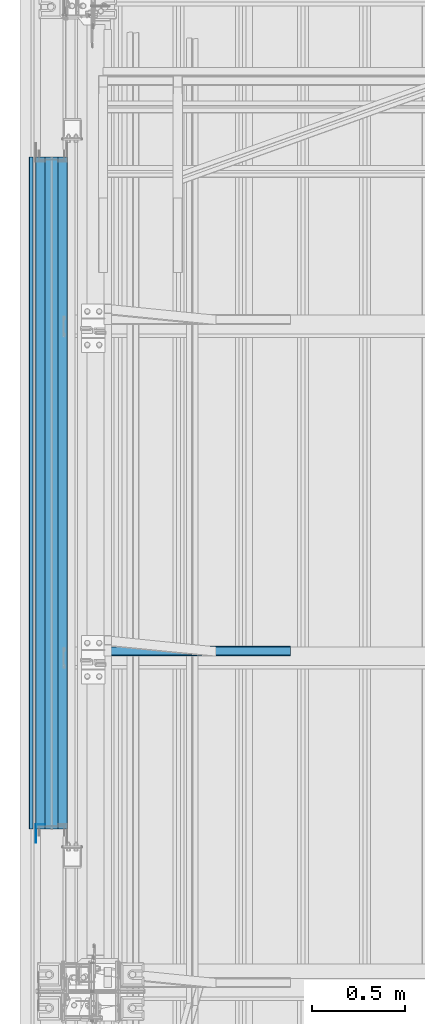
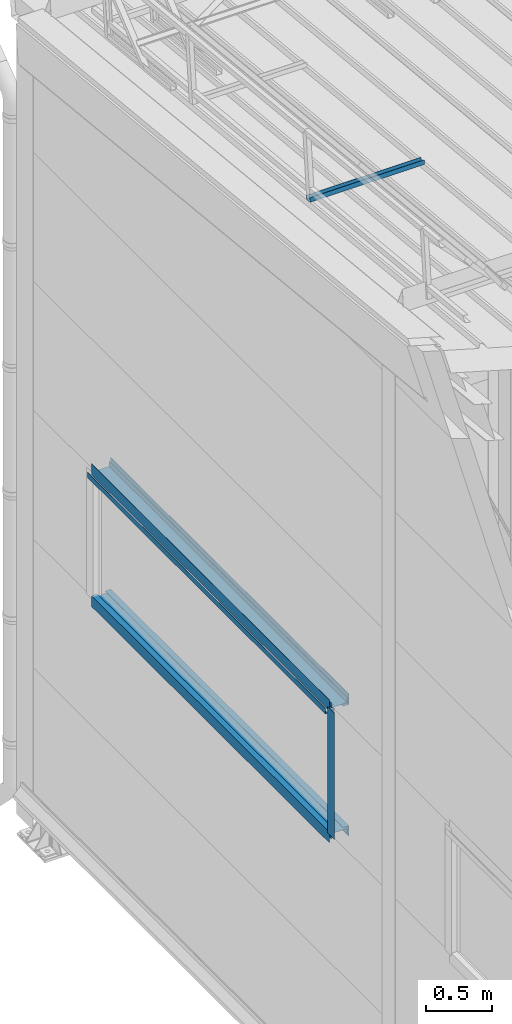
# One storey, part 49 of 709: 9 beams, 9 elements without a shape of their own.
"""IFC4 building model written with IfcOpenShell, lengths in millimetres."""

from ifc_helpers import new_model, si_unit, direction, frame, origin_with_axes, place, context, subcontext, project, spatial, line, indexed_curve, outline, extrude, material, element, aggregate, save


model = new_model("IFC4")

# Units and contexts
model_context = context("Model", 3, precision=0.2, world=origin_with_axes(), true_north=direction((0.0, 1.0)))
body_context = subcontext(model_context, "Body", "Model", "MODEL_VIEW")
ifc_project = project(units=[si_unit("LENGTHUNIT", "METRE", prefix="MILLI"), si_unit("AREAUNIT", "SQUARE_METRE"), si_unit("VOLUMEUNIT", "CUBIC_METRE"), si_unit("MASSUNIT", "GRAM", prefix="KILO"), si_unit("TIMEUNIT", "SECOND"), si_unit("PLANEANGLEUNIT", "RADIAN"), si_unit("SOLIDANGLEUNIT", "STERADIAN"), si_unit("THERMODYNAMICTEMPERATUREUNIT", "DEGREE_CELSIUS"), si_unit("LUMINOUSINTENSITYUNIT", "LUMEN")], contexts=[model_context])

# Site, building, storey
site_placement = place(None, origin_with_axes())
site = spatial("IfcSite", under=ifc_project, at=site_placement, CompositionType="ELEMENT")
building_placement = place(site_placement, origin_with_axes())
building = spatial("IfcBuilding", under=site, at=building_placement, Name="Undefined", CompositionType="ELEMENT")
storey_placement = place(building_placement, origin_with_axes())
storey = spatial("IfcBuildingStorey", under=building, at=storey_placement, Name="Undefined", CompositionType="ELEMENT", Elevation=0.0)

# Assembly, beam
assembly_1_placement = place(storey_placement, frame((220.0, 18323.4665, 7867.92296), z_axis=(0.0, 0.099503719, 0.9950371902), x_axis=(1.0, 0.0, 0.0)))
assembly_1 = element("IfcElementAssembly", 1, at=assembly_1_placement, inside=storey)
ifc_material = material(Name="Steel_Undefined", Category="STEEL")
beam_1_placement = place(assembly_1_placement, origin_with_axes())
beam_1 = element("IfcBeam", 2, at=beam_1_placement, material=ifc_material, ObjectType="601", context=body_context, shape_type="SolidModel", body=[
    extrude(outline(indexed_curve([(-20.0, -25.0), (20.0, -25.0), (20.0, -22.5), (-17.5, -22.5), (-17.5, 22.5), (20.0, 22.5), (20.0, 25.0), (-20.0, 25.0)], segments=[line(1, 2, 3, 4, 5, 6, 7, 8, 1)])), frame((0.0, 0.0, 0.0), z_axis=(-1.0, 0.0, 0.0), x_axis=(0.0, 0.0, 1.0)), (0.0, 0.0, -1.0), 1000.0),
])
aggregate(assembly_1, [beam_1])

assembly_2_placement = place(storey_placement, frame((-1.0, 20970.0, 2725.0), z_axis=(1.0, 0.0, 0.0), x_axis=(0.0, -1.0, 0.0)))
assembly_2 = element("IfcElementAssembly", 3, at=assembly_2_placement, inside=storey)
beam_2_placement = place(assembly_2_placement, origin_with_axes())
beam_2 = element("IfcBeam", 4, at=beam_2_placement, material=ifc_material, context=body_context, shape_type="SolidModel", body=[
    extrude(outline(indexed_curve([(-25.0, -1.0), (25.0, -1.0), (25.0, 99.0), (23.0, 99.0), (23.0, 1.0), (-25.0, 1.0)], segments=[line(1, 2, 3, 4, 5, 6, 1)])), frame((0.0, 0.0, 0.0), z_axis=(-1.0, 0.0, 0.0), x_axis=(0.0, 0.0, 1.0)), (0.0, 0.0, -1.0), 3600.0),
])
aggregate(assembly_2, [beam_2])

assembly_3_placement = place(storey_placement, frame((-60.0, 17370.0, 2680.0), z_axis=(1.0, 0.0, 0.0), x_axis=(0.0, 1.0, 0.0)))
assembly_3 = element("IfcElementAssembly", 5, at=assembly_3_placement, inside=storey)
beam_3_placement = place(assembly_3_placement, origin_with_axes())
beam_3 = element("IfcBeam", 6, at=beam_3_placement, material=ifc_material, context=body_context, shape_type="SolidModel", body=[
    extrude(outline(indexed_curve([(-70.0, -25.0), (-68.0, -25.0), (-68.0, 23.0), (68.0, 23.0), (68.0, -25.0), (70.0, -25.0), (70.0, 25.0), (-70.0, 25.0)], segments=[line(1, 2, 3, 4, 5, 6, 7, 8, 1)])), frame((0.0, 0.0, 0.0), z_axis=(-1.0, 0.0, 0.0), x_axis=(0.0, 0.0, 1.0)), (0.0, 0.0, -1.0), 3600.0),
])
aggregate(assembly_3, [beam_3])

assembly_4_placement = place(storey_placement, frame((-121.0, 17370.0, 2725.0), z_axis=(-1.0, 0.0, 0.0), x_axis=(0.0, 1.0, 0.0)))
assembly_4 = element("IfcElementAssembly", 7, at=assembly_4_placement, inside=storey)
beam_4_placement = place(assembly_4_placement, origin_with_axes())
beam_4 = element("IfcBeam", 8, at=beam_4_placement, material=ifc_material, context=body_context, shape_type="SolidModel", body=[
    extrude(outline(indexed_curve([(-25.0, -1.0), (25.0, -1.0), (25.0, 99.0), (23.0, 99.0), (23.0, 1.0), (-25.0, 1.0)], segments=[line(1, 2, 3, 4, 5, 6, 1)])), frame((0.0, 0.0, 0.0), z_axis=(-1.0, 0.0, 0.0), x_axis=(0.0, 0.0, 1.0)), (0.0, 0.0, -1.0), 3600.0),
])
aggregate(assembly_4, [beam_4])

assembly_5_placement = place(storey_placement, frame((-1.0, 17370.0, 3845.0), z_axis=(1.0, 0.0, 0.0), x_axis=(0.0, 1.0, 0.0)))
assembly_5 = element("IfcElementAssembly", 9, at=assembly_5_placement, inside=storey)
beam_5_placement = place(assembly_5_placement, origin_with_axes())
beam_5 = element("IfcBeam", 10, at=beam_5_placement, material=ifc_material, context=body_context, shape_type="SolidModel", body=[
    extrude(outline(indexed_curve([(-25.0, -1.0), (25.0, -1.0), (25.0, 99.0), (23.0, 99.0), (23.0, 1.0), (-25.0, 1.0)], segments=[line(1, 2, 3, 4, 5, 6, 1)])), frame((0.0, 0.0, 0.0), z_axis=(-1.0, 0.0, 0.0), x_axis=(0.0, 0.0, 1.0)), (0.0, 0.0, -1.0), 3600.0),
])
aggregate(assembly_5, [beam_5])

assembly_6_placement = place(storey_placement, frame((-60.0, 20970.0, 3890.0), z_axis=(1.0, 0.0, 0.0), x_axis=(0.0, -1.0, 0.0)))
assembly_6 = element("IfcElementAssembly", 11, at=assembly_6_placement, inside=storey)
beam_6_placement = place(assembly_6_placement, origin_with_axes())
beam_6 = element("IfcBeam", 12, at=beam_6_placement, material=ifc_material, context=body_context, shape_type="SolidModel", body=[
    extrude(outline(indexed_curve([(-70.0, -25.0), (-68.0, -25.0), (-68.0, 23.0), (68.0, 23.0), (68.0, -25.0), (70.0, -25.0), (70.0, 25.0), (-70.0, 25.0)], segments=[line(1, 2, 3, 4, 5, 6, 7, 8, 1)])), frame((0.0, 0.0, 0.0), z_axis=(-1.0, 0.0, 0.0), x_axis=(0.0, 0.0, 1.0)), (0.0, 0.0, -1.0), 3600.0),
])
aggregate(assembly_6, [beam_6])

assembly_7_placement = place(storey_placement, frame((-121.0, 20970.0, 3845.0), z_axis=(-1.0, 0.0, 0.0), x_axis=(0.0, -1.0, 0.0)))
assembly_7 = element("IfcElementAssembly", 13, at=assembly_7_placement, inside=storey)
beam_7_placement = place(assembly_7_placement, origin_with_axes())
beam_7 = element("IfcBeam", 14, at=beam_7_placement, material=ifc_material, context=body_context, shape_type="SolidModel", body=[
    extrude(outline(indexed_curve([(-25.0, -1.0), (25.0, -1.0), (25.0, 99.0), (23.0, 99.0), (23.0, 1.0), (-25.0, 1.0)], segments=[line(1, 2, 3, 4, 5, 6, 1)])), frame((0.0, 0.0, 0.0), z_axis=(-1.0, 0.0, 0.0), x_axis=(0.0, 0.0, 1.0)), (0.0, 0.0, -1.0), 3600.0),
])
aggregate(assembly_7, [beam_7])

assembly_8_placement = place(storey_placement, frame((-171.0, 20970.0, 3830.0), z_axis=(-1.0, 0.0, 0.0), x_axis=(0.0, -1.0, 0.0)))
assembly_8 = element("IfcElementAssembly", 15, at=assembly_8_placement, inside=storey)
beam_8_placement = place(assembly_8_placement, origin_with_axes())
beam_8 = element("IfcBeam", 16, at=beam_8_placement, material=ifc_material, context=body_context, shape_type="SolidModel", body=[
    extrude(outline(indexed_curve([(-10.0, -1.0), (10.0, -1.0), (10.0, 49.0), (8.0, 49.0), (8.0, 1.0), (-10.0, 1.0)], segments=[line(1, 2, 3, 4, 5, 6, 1)])), frame((0.0, 0.0, 0.0), z_axis=(-1.0, 0.0, 0.0), x_axis=(0.0, 0.0, 1.0)), (0.0, 0.0, -1.0), 3600.0),
])
aggregate(assembly_8, [beam_8])

assembly_9_placement = place(storey_placement, frame((-121.0, 17395.0, 3870.0), z_axis=(-1.0, 0.0, 0.0), x_axis=(0.0, 0.0, -1.0)))
assembly_9 = element("IfcElementAssembly", 17, at=assembly_9_placement, inside=storey)
beam_9_placement = place(assembly_9_placement, origin_with_axes())
beam_9 = element("IfcBeam", 18, at=beam_9_placement, material=ifc_material, context=body_context, shape_type="SolidModel", body=[
    extrude(outline(indexed_curve([(-25.0, -1.0), (25.0, -1.0), (25.0, 99.0), (23.0, 99.0), (23.0, 1.0), (-25.0, 1.0)], segments=[line(1, 2, 3, 4, 5, 6, 1)])), frame((0.0, 0.0, 0.0), z_axis=(-1.0, 0.0, 0.0), x_axis=(0.0, 0.0, 1.0)), (0.0, 0.0, -1.0), 1170.0),
])
aggregate(assembly_9, [beam_9])

save(model, "model.ifc")
